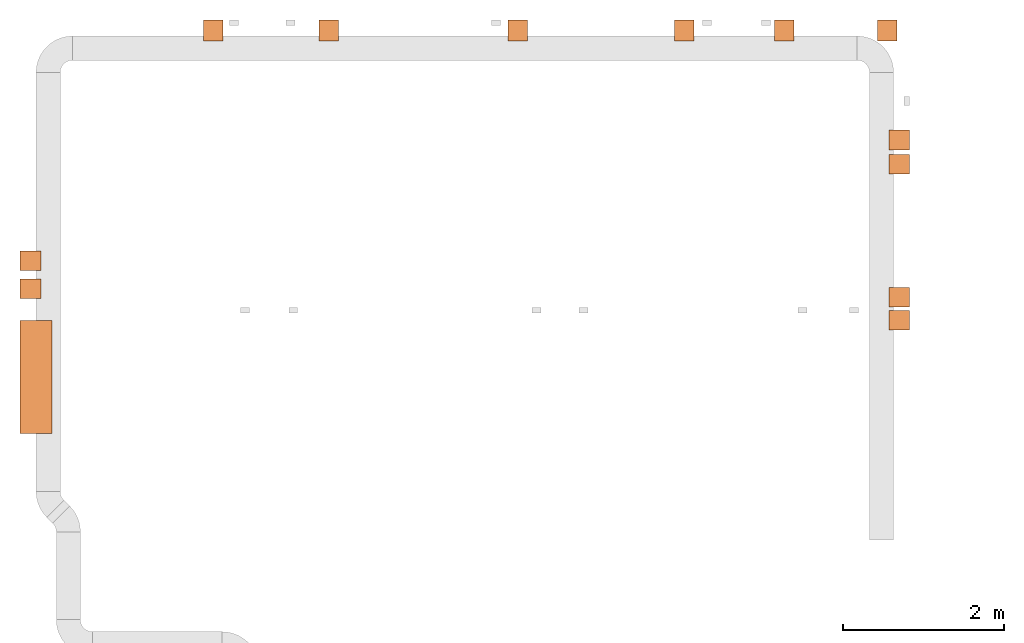
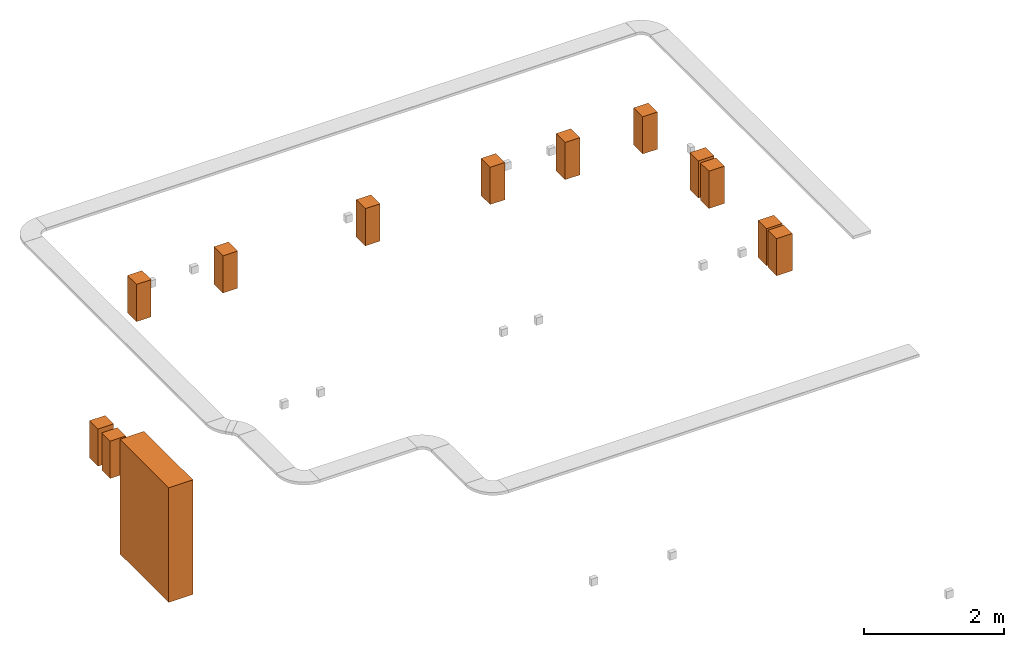
# One storey, part 2 of 2: 13 proxies.
"""IFC2X3 building model written with IfcOpenShell, lengths in millimetres."""

from ifc_helpers import new_model, entity, si_unit, converted_unit, derived_unit, direction, frame, origin, origin_2d_with_axis, place, context, subcontext, project, spatial, rectangle, extrude, source, transform, mapped, material, type_object, type_shapes, element, save


model = new_model("IFC2X3")

# Units and contexts
model_context = context("Model", 3, precision=0.01, world=origin(), true_north=direction((6.12303176911189e-17, 1.0)))
body_context = subcontext(model_context, "Body", "Model", "MODEL_VIEW")
ifc_project = project(units=[si_unit("LENGTHUNIT", "METRE", prefix="MILLI"), si_unit("AREAUNIT", "SQUARE_METRE"), si_unit("VOLUMEUNIT", "CUBIC_METRE"), converted_unit("PLANEANGLEUNIT", "DEGREE", entity("IfcRatioMeasure", 0.0174532925199433), si_unit("PLANEANGLEUNIT", "RADIAN"), dimensions=[0, 0, 0, 0, 0, 0, 0]), si_unit("MASSUNIT", "GRAM", prefix="KILO"), derived_unit("MASSDENSITYUNIT", [(si_unit("MASSUNIT", "GRAM", prefix="KILO"), 1), (si_unit("LENGTHUNIT", "METRE"), -3)]), derived_unit("MOMENTOFINERTIAUNIT", [(si_unit("LENGTHUNIT", "METRE"), 4)]), si_unit("TIMEUNIT", "SECOND"), si_unit("FREQUENCYUNIT", "HERTZ"), si_unit("THERMODYNAMICTEMPERATUREUNIT", "DEGREE_CELSIUS"), derived_unit("THERMALTRANSMITTANCEUNIT", [(si_unit("MASSUNIT", "GRAM", prefix="KILO"), 1), (si_unit("THERMODYNAMICTEMPERATUREUNIT", "KELVIN"), -1), (si_unit("TIMEUNIT", "SECOND"), -3)]), derived_unit("VOLUMETRICFLOWRATEUNIT", [(si_unit("LENGTHUNIT", "METRE"), 3), (si_unit("TIMEUNIT", "SECOND"), -1)]), derived_unit("MASSFLOWRATEUNIT", [(si_unit("MASSUNIT", "GRAM", prefix="KILO"), 1), (si_unit("TIMEUNIT", "SECOND"), -1)]), derived_unit("ROTATIONALFREQUENCYUNIT", [(si_unit("TIMEUNIT", "SECOND"), -1)]), si_unit("ELECTRICCURRENTUNIT", "AMPERE"), si_unit("ELECTRICVOLTAGEUNIT", "VOLT"), si_unit("POWERUNIT", "WATT"), si_unit("FORCEUNIT", "NEWTON", prefix="KILO"), si_unit("ILLUMINANCEUNIT", "LUX"), si_unit("LUMINOUSFLUXUNIT", "LUMEN"), si_unit("LUMINOUSINTENSITYUNIT", "CANDELA"), derived_unit("USERDEFINED", [(si_unit("MASSUNIT", "GRAM", prefix="KILO"), -1), (si_unit("LENGTHUNIT", "METRE"), -2), (si_unit("TIMEUNIT", "SECOND"), 3), (si_unit("LUMINOUSFLUXUNIT", "LUMEN"), 1)]), derived_unit("LINEARVELOCITYUNIT", [(si_unit("LENGTHUNIT", "METRE"), 1), (si_unit("TIMEUNIT", "SECOND"), -1)]), si_unit("PRESSUREUNIT", "PASCAL"), derived_unit("USERDEFINED", [(si_unit("LENGTHUNIT", "METRE"), -2), (si_unit("MASSUNIT", "GRAM", prefix="KILO"), 1), (si_unit("TIMEUNIT", "SECOND"), -2)]), derived_unit("LINEARFORCEUNIT", [(si_unit("MASSUNIT", "GRAM", prefix="KILO"), 1), (si_unit("LENGTHUNIT", "METRE"), 1), (si_unit("TIMEUNIT", "SECOND"), -2), (si_unit("LENGTHUNIT", "METRE"), -1)]), derived_unit("PLANARFORCEUNIT", [(si_unit("MASSUNIT", "GRAM", prefix="KILO"), 1), (si_unit("LENGTHUNIT", "METRE"), 1), (si_unit("TIMEUNIT", "SECOND"), -2), (si_unit("LENGTHUNIT", "METRE"), -2)])], contexts=[model_context])

# Site, building, storey
site_placement = place(None, origin())
site = spatial("IfcSite", under=ifc_project, at=site_placement, CompositionType="ELEMENT")
building_placement = place(site_placement, origin())
building = spatial("IfcBuilding", under=site, at=building_placement, CompositionType="ELEMENT")
storey_placement = place(building_placement, frame((0.0, 0.0, 199300.0)))
storey = spatial("IfcBuildingStorey", under=building, at=storey_placement, CompositionType="ELEMENT", Elevation=199300.0)

# Proxies
ifc_material = material()
building_element_proxy_type_1 = type_object("IfcBuildingElementProxyType", PredefinedType="NOTDEFINED", material=ifc_material)
shared_shape_1 = source(origin(), body_context, "Body", "SweptSolid", [
    extrude(rectangle(XDim=1400.0, YDim=400.000000000007, at=origin_2d_with_axis()), frame((0.0, 200.0, -2000.0), z_axis=(0.0, 0.0, 1.0), x_axis=(-1.0, 0.0, 0.0)), (0.0, 0.0, 1.0), 2000.0),
])
type_shapes(building_element_proxy_type_1, [shared_shape_1])
proxy_placement = place(storey_placement, frame((21170.1085349482, 15819.9992263563, 2000.0), z_axis=(0.0, 0.0, 1.0), x_axis=(0.0, -1.0, 0.0)))
element("IfcBuildingElementProxy", 1, at=proxy_placement, inside=storey, type_object=building_element_proxy_type_1, material=ifc_material, context=body_context, shape_type="MappedRepresentation", body=[
    mapped(shared_shape_1, transform((0.0, 0.0, 0.0), scale=1.0)),
])
building_element_proxy_type_2 = type_object("IfcBuildingElementProxyType", PredefinedType="NOTDEFINED", material=ifc_material)
shared_shape_2 = source(origin(), body_context, "Body", "SweptSolid", [
    extrude(rectangle(XDim=242.0, YDim=260.000000000006, at=origin_2d_with_axis()), frame((0.0, 130.0, -650.0), z_axis=(0.0, 0.0, 1.0), x_axis=(-1.0, 0.0, 0.0)), (0.0, 0.0, 1.0), 650.0),
])
type_shapes(building_element_proxy_type_2, [shared_shape_2])
for number, where, z_axis, x_axis in (
    (2, (23571.1085349482, 20249.999226356, 1800.0), (0.0, 0.0, 1.0), (-1.0, 0.0, 0.0)),
    (3, (24999.316077791, 20249.999226356, 1800.0), (0.0, 0.0, 1.0), (-1.0, 0.0, 0.0)),
    (4, (27349.1085349482, 20249.999226356, 1800.0), (0.0, 0.0, 1.0), (-1.0, 0.0, 0.0)),
    (5, (29411.1085349482, 20249.999226356, 1800.0), (0.0, 0.0, 1.0), (-1.0, 0.0, 0.0)),
    (6, (30651.1085349482, 20249.999226356, 1800.0), (0.0, 0.0, 1.0), (-1.0, 0.0, 0.0)),
    (7, (31931.1085349482, 20249.999226356, 1800.0), (0.0, 0.0, 1.0), (-1.0, 0.0, 0.0)),
    (8, (32210.0009155271, 18760.9992263562, 1800.0), (0.0, 0.0, 1.0), (0.0, 1.0, 0.0)),
    (9, (32210.0009155271, 18460.9992263562, 1800.0), (0.0, 0.0, 1.0), (0.0, 1.0, 0.0)),
    (10, (32210.0009155271, 16809.2410117257, 1800.0), (0.0, 0.0, 1.0), (0.0, 1.0, 0.0)),
    (11, (32210.0009155271, 16523.346550733, 1800.0), (0.0, 0.0, 1.0), (0.0, 1.0, 0.0)),
    (12, (21170.1085349482, 16914.1574209934, 1800.0), (0.0, 0.0, 1.0), (0.0, -1.0, 0.0)),
    (13, (21170.1085349482, 17264.6010907182, 1800.0), (0.0, 0.0, 1.0), (0.0, -1.0, 0.0)),
):
    element("IfcBuildingElementProxy", number, at=place(storey_placement, frame(where, z_axis=z_axis, x_axis=x_axis)), inside=storey, type_object=building_element_proxy_type_2, material=ifc_material, context=body_context, shape_type="MappedRepresentation", body=[
        mapped(shared_shape_2, transform((0.0, 0.0, 0.0), scale=1.0)),
    ])

save(model, "model.ifc")
